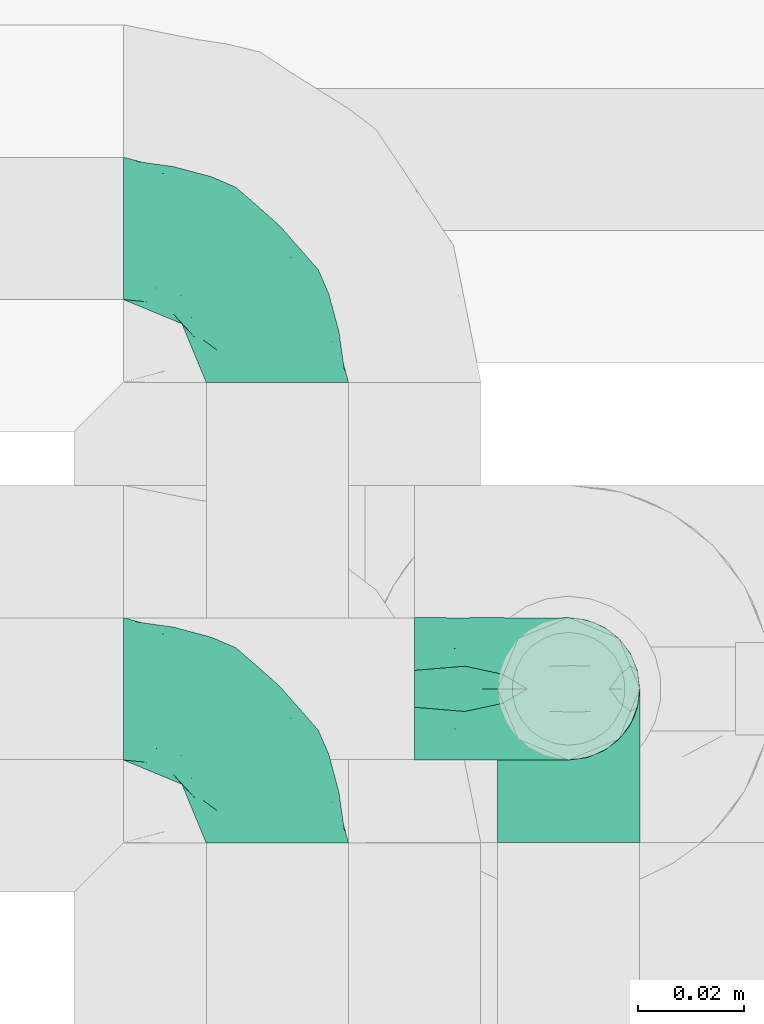
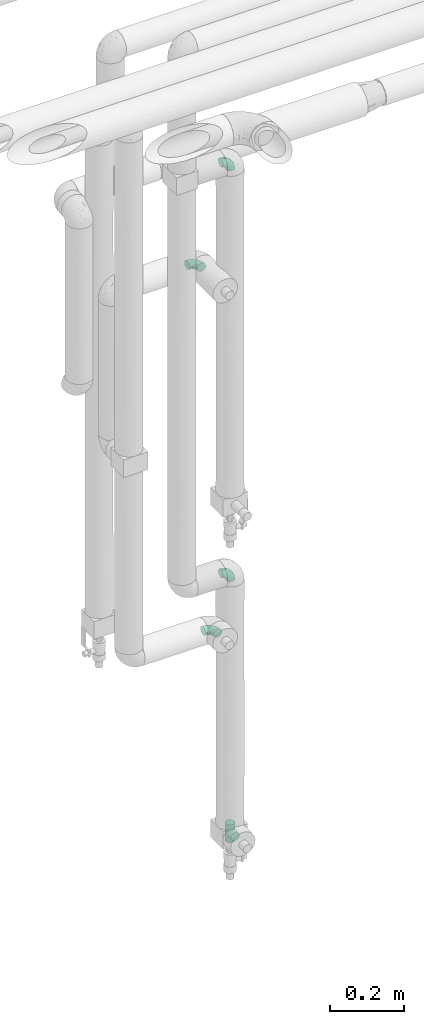
# One storey, part 760 of 827: 5 flow fittings.
"""IFC2X3 building model written with IfcOpenShell, lengths in millimetres."""

from ifc_helpers import new_model, entity, si_unit, converted_unit, derived_unit, direction, frame, origin, place, context, subcontext, project, spatial, faceted_brep, source, transform, mapped, material, type_object, type_shapes, element, save


model = new_model("IFC2X3")

# Units and contexts
model_context = context("Model", 3, precision=0.01, world=origin(), true_north=direction((6.12303176911189e-17, 1.0)))
body_context = subcontext(model_context, "Body", "Model", "MODEL_VIEW")
ifc_project = project(units=[si_unit("LENGTHUNIT", "METRE", prefix="MILLI"), si_unit("AREAUNIT", "SQUARE_METRE"), si_unit("VOLUMEUNIT", "CUBIC_METRE"), converted_unit("PLANEANGLEUNIT", "DEGREE", entity("IfcRatioMeasure", 0.0174532925199433), si_unit("PLANEANGLEUNIT", "RADIAN"), dimensions=[0, 0, 0, 0, 0, 0, 0]), si_unit("MASSUNIT", "GRAM", prefix="KILO"), derived_unit("MASSDENSITYUNIT", [(si_unit("MASSUNIT", "GRAM", prefix="KILO"), 1), (si_unit("LENGTHUNIT", "METRE"), -3)]), derived_unit("MOMENTOFINERTIAUNIT", [(si_unit("LENGTHUNIT", "METRE"), 4)]), si_unit("TIMEUNIT", "SECOND"), si_unit("FREQUENCYUNIT", "HERTZ"), si_unit("THERMODYNAMICTEMPERATUREUNIT", "DEGREE_CELSIUS"), derived_unit("THERMALTRANSMITTANCEUNIT", [(si_unit("MASSUNIT", "GRAM", prefix="KILO"), 1), (si_unit("THERMODYNAMICTEMPERATUREUNIT", "KELVIN"), -1), (si_unit("TIMEUNIT", "SECOND"), -3)]), derived_unit("VOLUMETRICFLOWRATEUNIT", [(si_unit("LENGTHUNIT", "METRE"), 3), (si_unit("TIMEUNIT", "SECOND"), -1)]), derived_unit("MASSFLOWRATEUNIT", [(si_unit("MASSUNIT", "GRAM", prefix="KILO"), 1), (si_unit("TIMEUNIT", "SECOND"), -1)]), derived_unit("ROTATIONALFREQUENCYUNIT", [(si_unit("TIMEUNIT", "SECOND"), -1)]), si_unit("ELECTRICCURRENTUNIT", "AMPERE"), si_unit("ELECTRICVOLTAGEUNIT", "VOLT"), si_unit("POWERUNIT", "WATT"), si_unit("FORCEUNIT", "NEWTON", prefix="KILO"), si_unit("ILLUMINANCEUNIT", "LUX"), si_unit("LUMINOUSFLUXUNIT", "LUMEN"), si_unit("LUMINOUSINTENSITYUNIT", "CANDELA"), derived_unit("USERDEFINED", [(si_unit("MASSUNIT", "GRAM", prefix="KILO"), -1), (si_unit("LENGTHUNIT", "METRE"), -2), (si_unit("TIMEUNIT", "SECOND"), 3), (si_unit("LUMINOUSFLUXUNIT", "LUMEN"), 1)]), derived_unit("LINEARVELOCITYUNIT", [(si_unit("LENGTHUNIT", "METRE"), 1), (si_unit("TIMEUNIT", "SECOND"), -1)]), si_unit("PRESSUREUNIT", "PASCAL"), derived_unit("USERDEFINED", [(si_unit("LENGTHUNIT", "METRE"), -2), (si_unit("MASSUNIT", "GRAM", prefix="KILO"), 1), (si_unit("TIMEUNIT", "SECOND"), -2)]), derived_unit("LINEARFORCEUNIT", [(si_unit("MASSUNIT", "GRAM", prefix="KILO"), 1), (si_unit("LENGTHUNIT", "METRE"), 1), (si_unit("TIMEUNIT", "SECOND"), -2), (si_unit("LENGTHUNIT", "METRE"), -1)]), derived_unit("PLANARFORCEUNIT", [(si_unit("MASSUNIT", "GRAM", prefix="KILO"), 1), (si_unit("LENGTHUNIT", "METRE"), 1), (si_unit("TIMEUNIT", "SECOND"), -2), (si_unit("LENGTHUNIT", "METRE"), -2)])], contexts=[model_context])

# Site, building, storey
site_placement = place(None, origin())
site = spatial("IfcSite", under=ifc_project, at=site_placement, CompositionType="ELEMENT")
building_placement = place(site_placement, origin())
building = spatial("IfcBuilding", under=site, at=building_placement, CompositionType="ELEMENT")
storey_placement = place(building_placement, frame((0.0, 0.0, 28200.0)))
storey = spatial("IfcBuildingStorey", under=building, at=storey_placement, Name="08", CompositionType="ELEMENT", Elevation=28200.0)

# Flow fittings
ifc_material = material()
pipe_fitting_type_1 = type_object("IfcPipeFittingType", Name="ADSK_1", PredefinedType="NOTDEFINED", material=ifc_material)
shared_shape_1 = source(origin(), body_context, "Body", "Brep", [
    faceted_brep([(-29.1, 0.0, -13.45), (-29.1, -3.48, -12.99), (-29.1, -6.73, -11.65), (-29.1, -9.51, -9.51), (-29.1, -11.65, -6.73), (-29.1, -12.99, -3.48), (-29.1, -13.45, 0.0), (-29.1, -12.99, 3.48), (-29.1, -11.65, 6.72), (-29.1, -9.51, 9.51), (-29.1, -6.73, 11.65), (-29.1, -3.48, 12.99), (-29.1, 0.0, 13.45), (-29.1, 3.48, 12.99), (-29.1, 6.72, 11.65), (-29.1, 9.51, 9.51), (-29.1, 11.65, 6.72), (-29.1, 12.99, 3.48), (-29.1, 13.45, 0.0), (-29.1, 12.99, -3.48), (-29.1, 11.65, -6.73), (-29.1, 9.51, -9.51), (-29.1, 6.72, -11.65), (-29.1, 3.48, -12.99), (-3.48, 29.1, -12.99), (-6.72, 29.1, -11.65), (-9.51, 29.1, -9.51), (-11.65, 29.1, -6.73), (-12.99, 29.1, -3.48), (-13.45, 29.1, 0.0), (-12.99, 29.1, 3.48), (-11.65, 29.1, 6.72), (-9.51, 29.1, 9.51), (-6.72, 29.1, 11.65), (-3.48, 29.1, 12.99), (0.0, 29.1, 13.45), (3.48, 29.1, 12.99), (6.73, 29.1, 11.65), (9.51, 29.1, 9.51), (11.65, 29.1, 6.72), (12.99, 29.1, 3.48), (13.45, 29.1, 0.0), (12.99, 29.1, -3.48), (11.65, 29.1, -6.73), (9.51, 29.1, -9.51), (6.73, 29.1, -11.65), (3.48, 29.1, -12.99), (0.0, 29.1, -13.45), (-19.62, -11.66, 4.28), (-21.41, -10.36, 7.6), (-16.26, -10.01, 0.0), (-12.48, -9.76, 2.75), (-10.66, 15.6, 11.91), (-15.27, 9.55, 12.42), (-10.71, 10.71, 13.09), (-0.04, 0.04, 0.0), (0.49, -0.45, 4.38), (-3.67, -4.15, 4.26), (-22.68, -11.73, 0.0), (-21.45, -4.97, 12.13), (-11.59, -2.84, 11.28), (-14.77, 0.17, 13.07), (-19.08, -7.58, 10.06), (-22.36, -1.69, 13.23), (-20.49, 2.21, 13.42), (-7.82, -7.75, 0.0), (-5.53, -2.55, 8.58), (-1.33, -0.87, 6.53), (-1.15, 1.15, 8.49), (-22.46, 5.38, 12.69), (-14.04, 21.05, 6.04), (-3.19, 3.19, 11.14), (-5.08, 25.05, 12.59), (-1.97, 21.79, 13.41), (-22.68, 11.31, 8.78), (-18.16, 12.64, 9.68), (-20.46, 14.33, 6.11), (-4.13, 10.11, 13.26), (-7.66, 3.08, 12.63), (-2.02, 8.24, 12.45), (-24.91, 8.22, 10.95), (-5.08, 14.28, 13.42), (-8.96, 6.48, 13.4), (-19.7, 16.14, 3.1), (-18.03, 18.03, 0.0), (-23.05, 15.96, 0.0), (-25.26, 12.69, 5.56), (4.97, 21.45, 12.13), (7.58, 19.08, 10.06), (1.69, 22.36, 13.23), (10.36, 21.41, 7.6), (8.11, 12.69, 6.86), (11.66, 19.62, 4.28), (-6.03, 19.65, 12.79), (9.76, 12.48, 2.75), (10.01, 16.26, 0.0), (-14.58, 16.06, 9.44), (-11.19, 23.14, 8.74), (-16.29, 16.8, 7.24), (-11.99, -5.68, 9.36), (-15.42, 20.78, 3.08), (5.79, 12.02, 9.27), (2.84, 11.59, 11.28), (2.55, 5.53, 8.58), (-15.74, 23.57, 0.0), (-15.96, 23.05, 0.0), (-24.62, 13.88, 2.39), (-8.61, 22.49, 11.12), (-14.98, 12.8, 11.14), (11.73, 22.68, 0.0), (-12.69, -8.11, 6.86), (7.75, 7.82, 0.0), (-15.98, 6.12, 13.19), (-14.48, 3.64, 13.45), (-19.6, 9.46, 11.31), (-8.3, 15.02, 12.85), (-0.17, 14.77, 13.07), (-6.9, -5.2, 6.52), (7.5, 8.93, 4.46), (5.22, 6.95, 6.56), (-8.85, -7.47, 4.42), (3.86, 3.93, 0.0), (4.18, 3.75, 4.31), (-23.57, 15.74, 0.0), (-3.93, -3.86, 0.0), (-21.79, 1.97, -13.41), (-11.31, 22.68, -8.78), (-14.33, 20.46, -6.11), (-12.69, 25.26, -5.56), (4.97, 21.45, -12.13), (2.84, 11.59, -11.28), (-0.17, 14.77, -13.07), (-25.05, 5.08, -12.59), (-16.8, 16.29, -7.24), (-20.78, 15.42, -3.08), (-16.14, 19.7, -3.1), (-12.02, -5.79, -9.27), (-11.59, -2.84, -11.28), (-5.53, -2.55, -8.58), (-23.14, 11.19, -8.74), (-22.49, 8.61, -11.12), (-1.33, -0.87, -6.53), (-3.67, -4.15, -4.26), (-6.9, -5.2, -6.52), (-19.65, 6.03, -12.79), (-15.6, 10.66, -11.91), (-14.28, 5.08, -13.42), (-10.71, 10.71, -13.09), (-6.48, 8.96, -13.4), (-19.62, -11.66, -4.28), (-21.41, -10.36, -7.6), (-12.48, -9.76, -2.75), (11.66, 19.62, -4.28), (-12.69, -8.11, -6.86), (-22.36, -1.69, -13.23), (-16.06, 14.58, -9.44), (5.68, 11.99, -9.36), (7.58, 19.08, -10.06), (-19.08, -7.58, -10.06), (-21.45, -4.97, -12.13), (-9.55, 15.27, -12.42), (-12.8, 14.98, -11.14), (-8.22, 24.91, -10.95), (10.36, 21.41, -7.6), (-5.38, 22.46, -12.69), (1.69, 22.36, -13.23), (-2.21, 20.49, -13.42), (-12.64, 18.16, -9.68), (-21.05, 14.04, -6.04), (9.76, 12.48, -2.75), (-10.11, 4.13, -13.26), (-3.08, 7.66, -12.63), (-8.24, 2.02, -12.45), (-13.88, 24.62, -2.39), (8.11, 12.69, -6.86), (-6.12, 15.98, -13.19), (-3.64, 14.48, -13.45), (-9.46, 19.6, -11.31), (-15.02, 8.3, -12.85), (-14.77, 0.17, -13.07), (-3.19, 3.19, -11.14), (5.22, 6.95, -6.56), (2.55, 5.53, -8.58), (0.49, -0.45, -4.38), (4.18, 3.75, -4.31), (-8.85, -7.47, -4.42), (-1.15, 1.15, -8.49), (7.5, 8.93, -4.46)], [[[0, 1, 2, 3, 4, 5, 6, 7, 8, 9, 10, 11, 12, 13, 14, 15, 16, 17, 18, 19, 20, 21, 22, 23]], [[24, 25, 26, 27, 28, 29, 30, 31, 32, 33, 34, 35, 36, 37, 38, 39, 40, 41, 42, 43, 44, 45, 46, 47]], [[48, 49, 8]], [[48, 50, 51]], [[52, 53, 54]], [[55, 56, 57]], [[49, 9, 8]], [[58, 48, 7]], [[59, 60, 61]], [[62, 10, 9]], [[62, 59, 10]], [[12, 63, 64]], [[51, 50, 65]], [[66, 67, 68]], [[12, 11, 63]], [[69, 14, 13]], [[31, 30, 70]], [[66, 71, 60]], [[34, 72, 73]], [[74, 75, 76]], [[77, 78, 79]], [[14, 80, 15]], [[16, 15, 74]], [[81, 54, 82]], [[83, 84, 85]], [[74, 76, 86]], [[37, 87, 88]], [[88, 38, 37]], [[36, 35, 89]], [[90, 91, 92]], [[93, 81, 73]], [[35, 34, 73]], [[10, 59, 11]], [[92, 94, 95]], [[96, 97, 98]], [[90, 92, 39]], [[99, 60, 62]], [[40, 39, 92]], [[87, 37, 36]], [[100, 84, 83]], [[50, 48, 58]], [[100, 83, 98]], [[101, 102, 103]], [[104, 105, 84, 100, 29]], [[48, 8, 7]], [[86, 17, 16]], [[106, 18, 17]], [[32, 97, 107]], [[53, 52, 108]], [[52, 93, 107]], [[97, 96, 107]], [[72, 107, 93]], [[72, 34, 33]], [[92, 109, 40]], [[33, 32, 107]], [[69, 13, 64]], [[88, 87, 102]], [[12, 64, 13]], [[49, 110, 62]], [[39, 38, 90]], [[95, 94, 111]], [[112, 113, 82]], [[53, 69, 112]], [[80, 74, 15]], [[114, 108, 75]], [[32, 31, 97]], [[115, 52, 54]], [[93, 115, 81]], [[89, 73, 116]], [[106, 76, 83]], [[106, 83, 85]], [[83, 76, 98]], [[100, 30, 29]], [[60, 59, 62]], [[63, 59, 61]], [[110, 117, 99]], [[60, 71, 78]], [[89, 87, 36]], [[116, 79, 102]], [[116, 102, 87]], [[102, 71, 103]], [[110, 49, 48]], [[62, 9, 49]], [[38, 88, 90]], [[91, 90, 88]], [[112, 69, 64]], [[80, 69, 114]], [[111, 94, 118]], [[119, 101, 103]], [[117, 66, 99]], [[117, 120, 57]], [[119, 91, 101]], [[66, 68, 71]], [[66, 117, 67]], [[121, 111, 122, 55]], [[56, 55, 122]], [[31, 70, 97]], [[97, 70, 98]], [[107, 96, 52]], [[53, 108, 114]], [[112, 82, 54]], [[116, 73, 81]], [[78, 82, 61]], [[81, 82, 77]], [[73, 89, 35]], [[87, 89, 116]], [[59, 63, 11]], [[64, 63, 61]], [[112, 64, 113]], [[53, 112, 54]], [[7, 6, 58]], [[109, 92, 95]], [[109, 41, 40]], [[69, 53, 114]], [[52, 96, 108]], [[75, 108, 96]], [[75, 96, 98]], [[114, 75, 74]], [[64, 61, 113]], [[61, 82, 113]], [[91, 88, 101]], [[110, 48, 51]], [[92, 91, 94]], [[91, 119, 118]], [[106, 85, 123, 18]], [[106, 17, 86]], [[60, 78, 61]], [[79, 78, 71]], [[102, 79, 71]], [[77, 79, 116]], [[81, 77, 116]], [[78, 77, 82]], [[69, 80, 14]], [[74, 80, 114]], [[74, 86, 16]], [[106, 86, 76]], [[107, 72, 33]], [[73, 72, 93]], [[98, 70, 100]], [[75, 98, 76]], [[30, 100, 70]], [[110, 99, 62]], [[66, 60, 99]], [[120, 110, 51]], [[67, 117, 57]], [[57, 56, 67]], [[67, 122, 119]], [[110, 120, 117]], [[65, 120, 51]], [[57, 65, 124, 55]], [[122, 67, 56]], [[67, 103, 68]], [[71, 68, 103]], [[65, 57, 120]], [[102, 101, 88]], [[67, 119, 103]], [[118, 119, 122]], [[118, 122, 111]], [[91, 118, 94]], [[81, 115, 54]], [[93, 52, 115]], [[23, 125, 0]], [[126, 127, 128]], [[129, 130, 131]], [[23, 22, 132]], [[133, 134, 135]], [[136, 137, 138]], [[21, 139, 140]], [[141, 142, 143]], [[144, 140, 145]], [[143, 136, 138]], [[146, 147, 148]], [[144, 132, 140]], [[5, 4, 149]], [[4, 3, 150]], [[45, 129, 46]], [[151, 50, 149]], [[152, 43, 42]], [[42, 41, 109]], [[150, 149, 4]], [[153, 149, 150]], [[154, 1, 0]], [[139, 155, 140]], [[156, 130, 157]], [[149, 58, 5]], [[18, 123, 85, 84, 134]], [[158, 159, 137]], [[84, 105, 135]], [[160, 145, 161]], [[143, 153, 136]], [[27, 26, 126]], [[25, 162, 26]], [[152, 163, 43]], [[25, 24, 164]], [[47, 165, 166]], [[158, 3, 2]], [[167, 127, 126]], [[20, 19, 168]], [[47, 46, 165]], [[44, 157, 45]], [[23, 132, 125]], [[44, 43, 163]], [[158, 2, 159]], [[47, 166, 24]], [[129, 45, 157]], [[164, 24, 166]], [[134, 84, 135]], [[95, 169, 152]], [[22, 21, 140]], [[144, 146, 125]], [[109, 152, 42]], [[95, 152, 109]], [[170, 171, 172]], [[155, 139, 133]], [[28, 27, 128]], [[159, 2, 1]], [[173, 29, 28]], [[50, 151, 65]], [[169, 95, 111]], [[163, 174, 157]], [[175, 176, 148]], [[160, 164, 175]], [[162, 126, 26]], [[177, 161, 167]], [[21, 20, 139]], [[144, 145, 178]], [[144, 178, 146]], [[154, 125, 179]], [[173, 127, 135]], [[173, 135, 105]], [[135, 127, 133]], [[134, 19, 18]], [[154, 159, 1]], [[179, 172, 137]], [[179, 137, 159]], [[137, 180, 138]], [[130, 129, 157]], [[165, 129, 131]], [[174, 181, 156]], [[130, 180, 171]], [[3, 158, 150]], [[153, 150, 158]], [[174, 163, 152]], [[157, 44, 163]], [[175, 164, 166]], [[162, 164, 177]], [[130, 182, 180]], [[181, 141, 182]], [[55, 183, 184]], [[65, 151, 185]], [[183, 55, 142]], [[156, 181, 182]], [[180, 182, 186]], [[181, 187, 184]], [[65, 142, 55, 124]], [[20, 168, 139]], [[139, 168, 133]], [[140, 155, 145]], [[160, 161, 177]], [[175, 148, 147]], [[179, 125, 146]], [[171, 148, 131]], [[146, 148, 170]], [[125, 154, 0]], [[159, 154, 179]], [[129, 165, 46]], [[166, 165, 131]], [[175, 166, 176]], [[160, 175, 147]], [[58, 149, 50]], [[58, 6, 5]], [[145, 160, 147]], [[164, 160, 177]], [[145, 155, 161]], [[167, 161, 155]], [[167, 155, 133]], [[177, 167, 126]], [[166, 131, 176]], [[131, 148, 176]], [[149, 153, 151]], [[153, 143, 185]], [[145, 147, 178]], [[174, 152, 169]], [[173, 105, 104, 29]], [[173, 28, 128]], [[130, 171, 131]], [[172, 171, 180]], [[137, 172, 180]], [[170, 172, 179]], [[146, 170, 179]], [[171, 170, 148]], [[164, 162, 25]], [[126, 162, 177]], [[126, 128, 27]], [[173, 128, 127]], [[140, 132, 22]], [[125, 132, 144]], [[133, 168, 134]], [[167, 133, 127]], [[19, 134, 168]], [[153, 158, 136]], [[137, 136, 158]], [[141, 143, 138]], [[185, 143, 142]], [[186, 141, 138]], [[183, 142, 141]], [[185, 142, 65]], [[153, 185, 151]], [[180, 186, 138]], [[182, 141, 186]], [[141, 184, 183]], [[184, 111, 121, 55]], [[174, 156, 157]], [[182, 130, 156]], [[187, 174, 169]], [[141, 181, 184]], [[174, 187, 181]], [[111, 187, 169]], [[111, 184, 187]], [[146, 178, 147]]]),
])
type_shapes(pipe_fitting_type_1, [shared_shape_1])
for number, where, z_axis, x_axis, name in (
    (1, (34840.42, 18334.91, 1230.0), (0.0, 1.0, 0.0), (1.0, 0.0, 0.0), "ADSK_1"),
    (2, (34840.42, 18334.91, 2580.0), (0.0, -1.0, 0.0), (0.0, 0.0, 1.0), "ADSK_1"),
):
    element("IfcFlowFitting", number, at=place(storey_placement, frame(where, z_axis=z_axis, x_axis=x_axis)), inside=storey, type_object=pipe_fitting_type_1, material=ifc_material, Name=name, ObjectType="ADSK_1", context=body_context, shape_type="MappedRepresentation", body=[
        mapped(shared_shape_1, transform((0.0, 0.0, 0.0), scale=1.0)),
    ])
pipe_fitting_type_2 = type_object("IfcPipeFittingType", Name="ADSK_1", PredefinedType="NOTDEFINED", material=ifc_material)
shared_shape_2 = source(origin(), body_context, "Body", "Brep", [
    faceted_brep([(-29.0, 3.48, -12.99), (-29.0, 0.0, -13.45), (-29.0, -3.48, -12.99), (-29.0, -6.73, -11.65), (-29.0, -9.51, -9.51), (-29.0, -11.65, -6.73), (-29.0, -12.99, -3.48), (-29.0, -13.45, 0.0), (-29.0, -12.99, 3.48), (-29.0, -11.65, 6.72), (-29.0, -9.51, 9.51), (-29.0, -6.73, 11.65), (-29.0, -3.48, 12.99), (-29.0, 0.0, 13.45), (-29.0, 3.48, 12.99), (-29.0, 6.72, 11.65), (-29.0, 9.51, 9.51), (-29.0, 11.65, 6.72), (-29.0, 12.99, 3.48), (-29.0, 13.45, 0.0), (-29.0, 12.99, -3.48), (-29.0, 11.65, -6.73), (-29.0, 9.51, -9.51), (-29.0, 6.72, -11.65), (29.0, 11.65, -6.73), (29.0, 12.99, -3.48), (29.0, 13.45, 0.0), (29.0, 12.99, 3.48), (29.0, 11.65, 6.72), (29.0, 9.51, 9.51), (29.0, 6.72, 11.65), (29.0, 3.48, 12.99), (29.0, 0.0, 13.45), (29.0, -3.48, 12.99), (29.0, -6.73, 11.65), (29.0, -9.51, 9.51), (29.0, -11.65, 6.72), (29.0, -12.99, 3.48), (29.0, -13.45, 0.0), (29.0, -12.99, -3.48), (29.0, -11.65, -6.73), (29.0, -9.51, -9.51), (29.0, -6.73, -11.65), (29.0, -3.48, -12.99), (29.0, 0.0, -13.45), (29.0, 3.48, -12.99), (29.0, 6.72, -11.65), (29.0, 9.51, -9.51), (12.96, -12.96, 3.59), (13.45, -13.45, 0.0), (-13.45, -13.45, 0.0), (11.64, -11.64, 6.74), (7.54, -7.54, 11.14), (9.76, -9.76, 9.25), (-12.96, -12.96, 3.59), (-11.64, -11.64, 6.74), (-9.76, -9.76, 9.25), (-7.54, -7.54, 11.14), (-5.12, -5.12, 12.44), (5.12, -5.12, 12.44), (2.58, -2.58, 13.2), (0.0, 0.0, 13.45), (-2.58, -2.58, 13.2), (2.58, -2.58, -13.2), (0.0, 0.0, -13.45), (-2.58, -2.58, -13.2), (-5.12, -5.12, -12.44), (5.12, -5.12, -12.44), (7.54, -7.54, -11.14), (9.76, -9.76, -9.25), (11.64, -11.64, -6.74), (12.96, -12.96, -3.59), (-7.54, -7.54, -11.14), (-9.76, -9.76, -9.25), (-12.96, -12.96, -3.59), (-11.64, -11.64, -6.74), (-12.99, -29.0, -3.48), (-11.65, -29.0, -6.73), (-9.51, -29.0, -9.51), (-6.72, -29.0, -11.65), (-3.48, -29.0, -12.99), (0.0, -29.0, -13.45), (3.48, -29.0, -12.99), (6.73, -29.0, -11.65), (9.51, -29.0, -9.51), (11.65, -29.0, -6.73), (12.99, -29.0, -3.48), (13.45, -29.0, 0.0), (12.99, -29.0, 3.48), (11.65, -29.0, 6.72), (9.51, -29.0, 9.51), (6.73, -29.0, 11.65), (3.48, -29.0, 12.99), (0.0, -29.0, 13.45), (-3.48, -29.0, 12.99), (-6.72, -29.0, 11.65), (-9.51, -29.0, 9.51), (-11.65, -29.0, 6.72), (-12.99, -29.0, 3.48), (-13.45, -29.0, 0.0)], [[[0, 1, 2, 3, 4, 5, 6, 7, 8, 9, 10, 11, 12, 13, 14, 15, 16, 17, 18, 19, 20, 21, 22, 23]], [[24, 25, 26, 27, 28, 29, 30, 31, 32, 33, 34, 35, 36, 37, 38, 39, 40, 41, 42, 43, 44, 45, 46, 47]], [[37, 36, 48]], [[38, 37, 49]], [[50, 8, 7]], [[49, 37, 48]], [[36, 51, 48]], [[35, 34, 52]], [[51, 36, 53]], [[52, 53, 35]], [[53, 36, 35]], [[50, 54, 8]], [[8, 54, 9]], [[54, 55, 9]], [[56, 57, 10]], [[10, 9, 56]], [[10, 57, 11]], [[56, 9, 55]], [[11, 57, 58]], [[52, 34, 59]], [[60, 32, 61]], [[62, 61, 13]], [[59, 33, 60]], [[33, 59, 34]], [[60, 33, 32]], [[61, 32, 31, 14, 13]], [[28, 27, 18, 17]], [[16, 15, 30, 29]], [[17, 16, 29, 28]], [[31, 30, 15, 14]], [[19, 18, 27, 26]], [[62, 12, 58]], [[12, 62, 13]], [[58, 12, 11]], [[47, 22, 21, 24]], [[25, 20, 19, 26]], [[25, 24, 21, 20]], [[23, 22, 47, 46]], [[44, 43, 63]], [[44, 64, 1, 0, 45]], [[64, 44, 63]], [[1, 64, 65]], [[46, 45, 0, 23]], [[65, 66, 2]], [[1, 65, 2]], [[66, 3, 2]], [[63, 43, 67]], [[42, 41, 68]], [[69, 68, 41]], [[40, 70, 69]], [[69, 41, 40]], [[42, 68, 67]], [[39, 38, 49]], [[6, 50, 7]], [[39, 71, 40]], [[71, 39, 49]], [[40, 71, 70]], [[72, 3, 66]], [[72, 4, 3]], [[4, 72, 73]], [[4, 73, 5]], [[74, 50, 6]], [[75, 74, 5]], [[74, 6, 5]], [[75, 5, 73]], [[42, 67, 43]], [[76, 77, 78, 79, 80, 81, 82, 83, 84, 85, 86, 87, 88, 89, 90, 91, 92, 93, 94, 95, 96, 97, 98, 99]], [[99, 98, 50]], [[54, 50, 98]], [[96, 95, 57]], [[97, 96, 56]], [[97, 54, 98]], [[58, 95, 94]], [[55, 54, 97]], [[56, 55, 97]], [[58, 57, 95]], [[93, 61, 62]], [[58, 94, 62]], [[56, 96, 57]], [[62, 94, 93]], [[60, 93, 92]], [[91, 59, 92]], [[89, 88, 48]], [[53, 90, 89]], [[52, 91, 90]], [[49, 88, 87]], [[59, 60, 92]], [[52, 59, 91]], [[49, 48, 88]], [[51, 53, 89]], [[48, 51, 89]], [[52, 90, 53]], [[93, 60, 61]], [[87, 86, 49]], [[71, 49, 86]], [[69, 85, 84]], [[68, 84, 83]], [[86, 85, 71]], [[67, 83, 82]], [[70, 71, 85]], [[69, 70, 85]], [[67, 68, 83]], [[81, 64, 63]], [[67, 82, 63]], [[69, 84, 68]], [[63, 82, 81]], [[65, 81, 80]], [[79, 66, 80]], [[77, 76, 74]], [[73, 78, 77]], [[72, 79, 78]], [[50, 76, 99]], [[66, 65, 80]], [[72, 66, 79]], [[50, 74, 76]], [[75, 73, 77]], [[74, 75, 77]], [[72, 78, 73]], [[81, 65, 64]]]),
])
type_shapes(pipe_fitting_type_2, [shared_shape_2])
flow_fitting_placement = place(storey_placement, frame((34840.42, 18334.91, 372.0), z_axis=(1.0, 0.0, 0.0), x_axis=(0.0, 0.0, -1.0)))
element("IfcFlowFitting", 3, at=flow_fitting_placement, inside=storey, type_object=pipe_fitting_type_2, material=ifc_material, Name="ADSK_1", ObjectType="ADSK_1", context=body_context, shape_type="MappedRepresentation", body=[
    mapped(shared_shape_2, transform((0.0, 0.0, 0.0), scale=1.0)),
])
pipe_fitting_type_3 = type_object("IfcPipeFittingType", Name="ADSK_1", PredefinedType="NOTDEFINED", material=ifc_material)
shared_shape_3 = source(origin(), body_context, "Body", "Brep", [
    faceted_brep([(-29.1, -3.48, -12.99), (-29.1, -6.72, -11.65), (-29.1, -9.51, -9.51), (-29.1, -11.65, -6.73), (-29.1, -12.99, -3.48), (-29.1, -13.45, 0.0), (-29.1, -12.99, 3.48), (-29.1, -11.65, 6.72), (-29.1, -9.51, 9.51), (-29.1, -6.72, 11.65), (-29.1, -3.48, 12.99), (-29.1, 0.0, 13.45), (-29.1, 3.48, 12.99), (-29.1, 6.73, 11.65), (-29.1, 9.51, 9.51), (-29.1, 11.65, 6.72), (-29.1, 12.99, 3.48), (-29.1, 13.45, 0.0), (-29.1, 12.99, -3.48), (-29.1, 11.65, -6.73), (-29.1, 9.51, -9.51), (-29.1, 6.73, -11.65), (-29.1, 3.48, -12.99), (-29.1, 0.0, -13.45), (0.0, -29.1, -13.45), (3.48, -29.1, -12.99), (6.73, -29.1, -11.65), (9.51, -29.1, -9.51), (11.65, -29.1, -6.73), (12.99, -29.1, -3.48), (13.45, -29.1, 0.0), (12.99, -29.1, 3.48), (11.65, -29.1, 6.72), (9.51, -29.1, 9.51), (6.73, -29.1, 11.65), (3.48, -29.1, 12.99), (0.0, -29.1, 13.45), (-3.48, -29.1, 12.99), (-6.72, -29.1, 11.65), (-9.51, -29.1, 9.51), (-11.65, -29.1, 6.72), (-12.99, -29.1, 3.48), (-13.45, -29.1, 0.0), (-12.99, -29.1, -3.48), (-11.65, -29.1, -6.73), (-9.51, -29.1, -9.51), (-6.72, -29.1, -11.65), (-3.48, -29.1, -12.99), (-21.41, 10.36, 7.6), (-19.62, 11.66, 4.28), (-12.48, 9.76, 2.75), (-16.26, 10.01, 0.0), (-10.71, -10.71, 13.09), (-15.27, -9.55, 12.42), (-10.66, -15.6, 11.91), (-3.67, 4.15, 4.26), (0.49, 0.45, 4.38), (-0.04, -0.04, 0.0), (-22.68, 11.73, 0.0), (-14.77, -0.17, 13.07), (-11.59, 2.84, 11.28), (-21.45, 4.97, 12.13), (-19.08, 7.58, 10.06), (-20.49, -2.21, 13.42), (-22.36, 1.69, 13.23), (-7.82, 7.75, 0.0), (-1.15, -1.15, 8.49), (-1.33, 0.87, 6.53), (-5.53, 2.55, 8.58), (-22.46, -5.38, 12.69), (-14.04, -21.05, 6.04), (-3.19, -3.19, 11.14), (-1.97, -21.79, 13.41), (-5.08, -25.05, 12.59), (-20.46, -14.33, 6.11), (-18.16, -12.64, 9.68), (-22.68, -11.31, 8.78), (-2.02, -8.24, 12.45), (-7.66, -3.08, 12.63), (-4.13, -10.11, 13.26), (-24.91, -8.22, 10.95), (-8.96, -6.48, 13.4), (-5.08, -14.28, 13.42), (-23.05, -15.96, 0.0), (-18.03, -18.03, 0.0), (-19.7, -16.14, 3.1), (-25.26, -12.69, 5.56), (7.58, -19.08, 10.06), (4.97, -21.45, 12.13), (1.69, -22.36, 13.23), (11.66, -19.62, 4.28), (8.11, -12.69, 6.86), (10.36, -21.41, 7.6), (-6.03, -19.65, 12.79), (10.01, -16.26, 0.0), (9.76, -12.48, 2.75), (-16.29, -16.8, 7.24), (-11.19, -23.14, 8.74), (-14.58, -16.06, 9.44), (-11.99, 5.68, 9.36), (-15.42, -20.78, 3.08), (2.55, -5.53, 8.58), (2.84, -11.59, 11.28), (5.79, -12.02, 9.27), (-15.96, -23.05, 0.0), (-15.74, -23.57, 0.0), (-24.62, -13.88, 2.39), (-8.61, -22.49, 11.12), (-14.98, -12.8, 11.14), (11.73, -22.68, 0.0), (-12.69, 8.11, 6.86), (7.75, -7.82, 0.0), (-14.48, -3.64, 13.45), (-15.98, -6.12, 13.19), (-19.6, -9.46, 11.31), (-8.3, -15.02, 12.85), (-0.17, -14.77, 13.07), (-6.9, 5.2, 6.52), (7.5, -8.93, 4.46), (5.22, -6.95, 6.56), (-8.85, 7.47, 4.42), (4.18, -3.75, 4.31), (3.86, -3.93, 0.0), (-23.57, -15.74, 0.0), (-3.93, 3.86, 0.0), (-21.79, -1.97, -13.41), (-12.69, -25.26, -5.56), (-14.33, -20.46, -6.11), (-11.31, -22.68, -8.78), (-0.17, -14.77, -13.07), (2.84, -11.59, -11.28), (4.97, -21.45, -12.13), (-25.05, -5.08, -12.59), (-16.14, -19.7, -3.1), (-20.78, -15.42, -3.08), (-16.8, -16.29, -7.24), (-5.53, 2.55, -8.58), (-11.59, 2.84, -11.28), (-12.02, 5.79, -9.27), (-22.49, -8.61, -11.12), (-23.14, -11.19, -8.74), (-6.9, 5.2, -6.52), (-3.67, 4.15, -4.26), (-1.33, 0.87, -6.53), (-15.6, -10.66, -11.91), (-19.65, -6.03, -12.79), (-6.48, -8.96, -13.4), (-10.71, -10.71, -13.09), (-14.28, -5.08, -13.42), (-19.62, 11.66, -4.28), (-21.41, 10.36, -7.6), (-12.48, 9.76, -2.75), (11.66, -19.62, -4.28), (-12.69, 8.11, -6.86), (-22.36, 1.69, -13.23), (-16.06, -14.58, -9.44), (7.58, -19.08, -10.06), (5.68, -11.99, -9.36), (-21.45, 4.97, -12.13), (-19.08, 7.58, -10.06), (-12.8, -14.98, -11.14), (-9.55, -15.27, -12.42), (-8.22, -24.91, -10.95), (10.36, -21.41, -7.6), (-5.38, -22.46, -12.69), (-2.21, -20.49, -13.42), (1.69, -22.36, -13.23), (-12.64, -18.16, -9.68), (-21.05, -14.04, -6.04), (9.76, -12.48, -2.75), (-8.24, -2.02, -12.45), (-3.08, -7.66, -12.63), (-10.11, -4.13, -13.26), (-13.88, -24.62, -2.39), (8.11, -12.69, -6.86), (-3.64, -14.48, -13.45), (-6.12, -15.98, -13.19), (-9.46, -19.6, -11.31), (-15.02, -8.3, -12.85), (-14.77, -0.17, -13.07), (-3.19, -3.19, -11.14), (5.22, -6.95, -6.56), (2.55, -5.53, -8.58), (4.18, -3.75, -4.31), (0.49, 0.45, -4.38), (-8.85, 7.47, -4.42), (-1.15, -1.15, -8.49), (7.5, -8.93, -4.46)], [[[0, 1, 2, 3, 4, 5, 6, 7, 8, 9, 10, 11, 12, 13, 14, 15, 16, 17, 18, 19, 20, 21, 22, 23]], [[24, 25, 26, 27, 28, 29, 30, 31, 32, 33, 34, 35, 36, 37, 38, 39, 40, 41, 42, 43, 44, 45, 46, 47]], [[15, 48, 49]], [[50, 51, 49]], [[52, 53, 54]], [[55, 56, 57]], [[15, 14, 48]], [[16, 49, 58]], [[59, 60, 61]], [[14, 13, 62]], [[13, 61, 62]], [[63, 64, 11]], [[65, 51, 50]], [[66, 67, 68]], [[64, 12, 11]], [[10, 9, 69]], [[70, 41, 40]], [[60, 71, 68]], [[72, 73, 37]], [[74, 75, 76]], [[77, 78, 79]], [[8, 80, 9]], [[76, 8, 7]], [[81, 52, 82]], [[83, 84, 85]], [[86, 74, 76]], [[87, 88, 34]], [[34, 33, 87]], [[89, 36, 35]], [[90, 91, 92]], [[72, 82, 93]], [[72, 37, 36]], [[12, 61, 13]], [[94, 95, 90]], [[96, 97, 98]], [[32, 90, 92]], [[62, 60, 99]], [[90, 32, 31]], [[35, 34, 88]], [[85, 84, 100]], [[58, 49, 51]], [[96, 85, 100]], [[101, 102, 103]], [[42, 100, 84, 104, 105]], [[16, 15, 49]], [[7, 6, 86]], [[6, 5, 106]], [[107, 97, 39]], [[108, 54, 53]], [[107, 93, 54]], [[107, 98, 97]], [[93, 107, 73]], [[38, 37, 73]], [[31, 109, 90]], [[107, 39, 38]], [[63, 10, 69]], [[102, 88, 87]], [[10, 63, 11]], [[62, 110, 48]], [[92, 33, 32]], [[111, 95, 94]], [[81, 112, 113]], [[113, 69, 53]], [[8, 76, 80]], [[75, 108, 114]], [[97, 40, 39]], [[52, 54, 115]], [[82, 115, 93]], [[116, 72, 89]], [[85, 74, 106]], [[83, 85, 106]], [[96, 74, 85]], [[42, 41, 100]], [[62, 61, 60]], [[59, 61, 64]], [[99, 117, 110]], [[78, 71, 60]], [[35, 88, 89]], [[102, 77, 116]], [[88, 102, 116]], [[101, 71, 102]], [[49, 48, 110]], [[48, 14, 62]], [[92, 87, 33]], [[87, 92, 91]], [[63, 69, 113]], [[114, 69, 80]], [[118, 95, 111]], [[101, 103, 119]], [[99, 68, 117]], [[55, 120, 117]], [[103, 91, 119]], [[71, 66, 68]], [[67, 117, 68]], [[121, 111, 122, 57]], [[121, 57, 56]], [[97, 70, 40]], [[96, 70, 97]], [[54, 98, 107]], [[114, 108, 53]], [[52, 81, 113]], [[82, 72, 116]], [[59, 81, 78]], [[79, 81, 82]], [[36, 89, 72]], [[116, 89, 88]], [[12, 64, 61]], [[59, 64, 63]], [[112, 63, 113]], [[52, 113, 53]], [[58, 17, 16]], [[94, 90, 109]], [[31, 30, 109]], [[114, 53, 69]], [[108, 98, 54]], [[98, 108, 75]], [[96, 98, 75]], [[76, 75, 114]], [[112, 59, 63]], [[112, 81, 59]], [[103, 87, 91]], [[50, 49, 110]], [[95, 91, 90]], [[118, 119, 91]], [[106, 5, 123, 83]], [[86, 6, 106]], [[59, 78, 60]], [[71, 78, 77]], [[71, 77, 102]], [[116, 77, 79]], [[116, 79, 82]], [[81, 79, 78]], [[9, 80, 69]], [[114, 80, 76]], [[7, 86, 76]], [[74, 86, 106]], [[38, 73, 107]], [[93, 73, 72]], [[100, 70, 96]], [[74, 96, 75]], [[70, 100, 41]], [[62, 99, 110]], [[99, 60, 68]], [[50, 110, 120]], [[55, 117, 67]], [[67, 56, 55]], [[119, 121, 67]], [[117, 120, 110]], [[50, 120, 65]], [[124, 65, 55, 57]], [[56, 67, 121]], [[66, 101, 67]], [[101, 66, 71]], [[120, 55, 65]], [[87, 103, 102]], [[101, 119, 67]], [[121, 119, 118]], [[111, 121, 118]], [[95, 118, 91]], [[52, 115, 82]], [[115, 54, 93]], [[23, 125, 0]], [[126, 127, 128]], [[129, 130, 131]], [[132, 1, 0]], [[133, 134, 135]], [[136, 137, 138]], [[139, 140, 2]], [[141, 142, 143]], [[144, 139, 145]], [[136, 138, 141]], [[146, 147, 148]], [[139, 132, 145]], [[149, 19, 18]], [[150, 20, 19]], [[25, 131, 26]], [[149, 51, 151]], [[29, 28, 152]], [[109, 30, 29]], [[19, 149, 150]], [[150, 149, 153]], [[23, 22, 154]], [[139, 155, 140]], [[156, 130, 157]], [[18, 58, 149]], [[134, 84, 83, 123, 5]], [[137, 158, 159]], [[133, 104, 84]], [[160, 144, 161]], [[138, 153, 141]], [[128, 45, 44]], [[45, 162, 46]], [[28, 163, 152]], [[164, 47, 46]], [[165, 166, 24]], [[21, 20, 159]], [[128, 127, 167]], [[168, 4, 3]], [[166, 25, 24]], [[26, 156, 27]], [[125, 132, 0]], [[163, 28, 27]], [[158, 21, 159]], [[47, 165, 24]], [[156, 26, 131]], [[165, 47, 164]], [[133, 84, 134]], [[152, 169, 94]], [[139, 2, 1]], [[125, 148, 145]], [[29, 152, 109]], [[109, 152, 94]], [[170, 171, 172]], [[135, 140, 155]], [[126, 44, 43]], [[22, 21, 158]], [[43, 42, 173]], [[65, 151, 51]], [[111, 94, 169]], [[156, 174, 163]], [[146, 175, 176]], [[176, 164, 161]], [[45, 128, 162]], [[167, 160, 177]], [[140, 3, 2]], [[178, 144, 145]], [[148, 178, 145]], [[179, 125, 154]], [[133, 127, 173]], [[104, 133, 173]], [[135, 127, 133]], [[5, 4, 134]], [[22, 158, 154]], [[137, 170, 179]], [[158, 137, 179]], [[136, 180, 137]], [[156, 131, 130]], [[129, 131, 166]], [[157, 181, 174]], [[171, 180, 130]], [[150, 159, 20]], [[159, 150, 153]], [[152, 163, 174]], [[163, 27, 156]], [[165, 164, 176]], [[177, 164, 162]], [[180, 182, 130]], [[182, 143, 181]], [[183, 184, 57]], [[185, 151, 65]], [[142, 57, 184]], [[182, 181, 157]], [[186, 182, 180]], [[183, 187, 181]], [[124, 57, 142, 65]], [[140, 168, 3]], [[135, 168, 140]], [[144, 155, 139]], [[177, 160, 161]], [[147, 146, 176]], [[148, 125, 179]], [[129, 146, 171]], [[172, 146, 148]], [[23, 154, 125]], [[179, 154, 158]], [[25, 166, 131]], [[129, 166, 165]], [[175, 165, 176]], [[147, 176, 161]], [[51, 149, 58]], [[18, 17, 58]], [[147, 161, 144]], [[177, 161, 164]], [[160, 155, 144]], [[155, 160, 167]], [[135, 155, 167]], [[128, 167, 177]], [[175, 129, 165]], [[175, 146, 129]], [[151, 153, 149]], [[185, 141, 153]], [[178, 147, 144]], [[169, 152, 174]], [[173, 42, 105, 104]], [[126, 43, 173]], [[129, 171, 130]], [[180, 171, 170]], [[180, 170, 137]], [[179, 170, 172]], [[179, 172, 148]], [[146, 172, 171]], [[46, 162, 164]], [[177, 162, 128]], [[44, 126, 128]], [[127, 126, 173]], [[1, 132, 139]], [[145, 132, 125]], [[134, 168, 135]], [[127, 135, 167]], [[168, 134, 4]], [[138, 159, 153]], [[159, 138, 137]], [[136, 141, 143]], [[142, 141, 185]], [[136, 143, 186]], [[143, 142, 184]], [[65, 142, 185]], [[151, 185, 153]], [[136, 186, 180]], [[186, 143, 182]], [[184, 183, 143]], [[122, 111, 183, 57]], [[156, 157, 174]], [[157, 130, 182]], [[169, 174, 187]], [[183, 181, 143]], [[181, 187, 174]], [[169, 187, 111]], [[187, 183, 111]], [[147, 178, 148]]]),
])
type_shapes(pipe_fitting_type_3, [shared_shape_3])
for number, where, name in (
    (4, (34785.39, 18334.91, 1060.0), "ADSK_1"),
    (5, (34785.39, 18421.91, 2210.0), "ADSK_1"),
):
    element("IfcFlowFitting", number, at=place(storey_placement, frame(where)), inside=storey, type_object=pipe_fitting_type_3, material=ifc_material, Name=name, ObjectType="ADSK_1", context=body_context, shape_type="MappedRepresentation", body=[
        mapped(shared_shape_3, transform((0.0, 0.0, 0.0), scale=1.0)),
    ])

save(model, "model.ifc")
